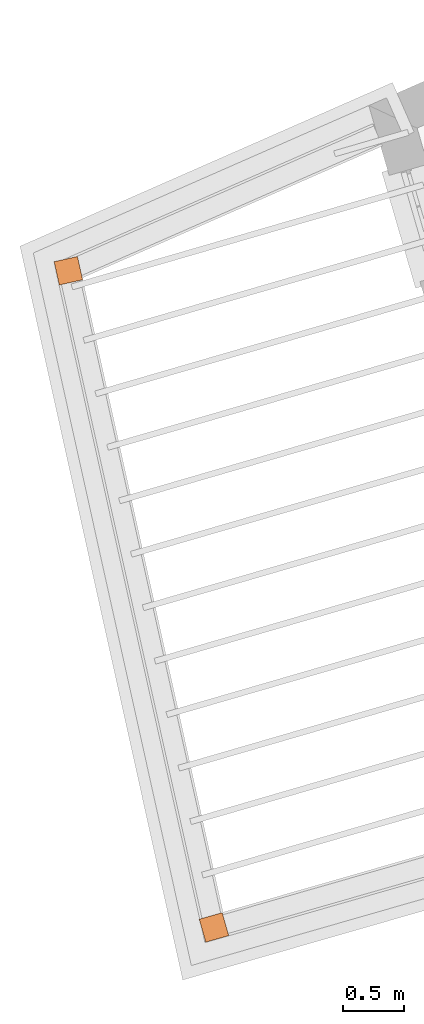
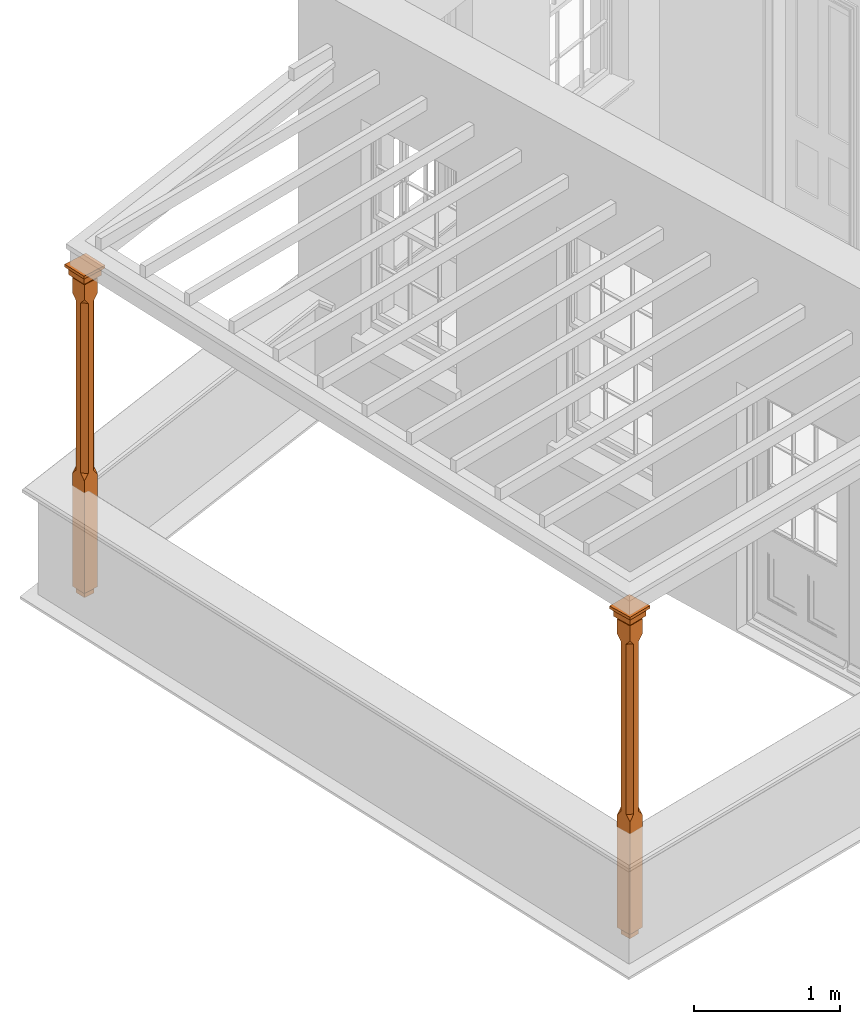
# One storey, part 11 of 11: 2 proxies.
"""IFC2X3 building model written with IfcOpenShell, lengths in metres."""

from ifc_helpers import new_model, si_unit, frame, origin, place, context, subcontext, project, spatial, faceted_brep, element, save


model = new_model("IFC2X3")

# Units and contexts
model_context = context("Model", 3, world=origin())
body_context = subcontext(model_context, "Body", "Model", "MODEL_VIEW")
ifc_project = project(units=[si_unit("PLANEANGLEUNIT", "RADIAN"), si_unit("MASSUNIT", "GRAM", prefix="KILO"), si_unit("FORCEUNIT", "NEWTON", prefix="KILO"), si_unit("LENGTHUNIT", "METRE")], contexts=[model_context])

# Site, building, storey
site_placement = place(None, origin())
site = spatial("IfcSite", under=ifc_project, at=site_placement, CompositionType="ELEMENT")
building_placement = place(None, origin())
building = spatial("IfcBuilding", under=site, at=building_placement, Name="Building plot-15", CompositionType="ELEMENT")
storey_placement = place(None, frame((0.0, 0.0, 7.6)))
storey = spatial("IfcBuildingStorey", under=building, at=storey_placement, Name="Floor 1", CompositionType="ELEMENT", Elevation=7.6)

# Proxies
proxy_1_placement = place(storey_placement, frame((82.8159321906737, 54.848405925525, 0.0), z_axis=(0.0, 0.0, 1.0), x_axis=(0.216502363571399, -0.976282093745449, 0.0)))
element("IfcBuildingElementProxy", 1, at=proxy_1_placement, inside=storey, Name="pergola post", CompositionType="ELEMENT", context=body_context, shape_type="Brep", held_by="IfcProductRepresentation", body=[
    faceted_brep([(0.0246, -0.0615, 2.47), (0.0615, -0.0246, 2.47), (0.0615, -0.0615, 2.516667), (0.0615, -0.0246, 1.044444), (0.0246, -0.0615, 1.044444), (0.0615, 0.0246, 2.47), (0.0615, 0.0615, 2.516667), (-0.0246, -0.0615, 2.47), (-0.0615, -0.0615, 2.516667), (-0.0246, -0.0615, 1.044444), (0.0615, -0.0615, 0.997778), (0.0615, 0.0246, 1.044444), (0.0246, 0.0615, 2.47), (0.0615, 0.0615, 2.641111), (0.0615, -0.0615, 2.641111), (-0.0615, -0.0615, 2.641111), (-0.0615, -0.0246, 2.47), (-0.0615, -0.0246, 1.044444), (-0.0615, -0.0615, 0.997778), (0.0615, 0.0615, 0.997778), (0.0246, 0.0615, 1.044444), (-0.0246, 0.0615, 2.47), (-0.0615, 0.0615, 2.516667), (0.04305, 0.04305, 2.641111), (0.04305, -0.04305, 2.641111), (-0.0615, 0.0615, 2.641111), (-0.04305, -0.04305, 2.641111), (-0.0615, 0.0246, 2.47), (-0.0615, 0.0246, 1.044444), (0.0615, -0.0615, 0.053333), (-0.0615, -0.0615, 0.053333), (0.0615, 0.0615, 0.053333), (-0.0246, 0.0615, 1.044444), (-0.04305, 0.04305, 2.641111), (0.04305, 0.04305, 2.664444), (0.04305, -0.04305, 2.664444), (-0.04305, -0.04305, 2.664444), (-0.0615, 0.0615, 0.997778), (-0.0615, 0.0615, 0.053333), (-0.04305, -0.04305, 0.053333), (0.04305, -0.04305, 0.053333), (0.04305, 0.04305, 0.053333), (-0.04305, 0.04305, 2.664444), (0.07995, 0.07995, 2.664444), (0.07995, -0.07995, 2.664444), (-0.07995, -0.07995, 2.664444), (-0.04305, 0.04305, 0.053333), (-0.04305, -0.04305, 0.0), (0.04305, -0.04305, 0.0), (0.04305, 0.04305, 0.0), (-0.07995, 0.07995, 2.664444), (0.07995, 0.07995, 2.726667), (0.07995, -0.07995, 2.726667), (-0.07995, -0.07995, 2.726667), (-0.04305, 0.04305, 0.0), (-0.07995, 0.07995, 2.726667), (0.0984, 0.0984, 2.726667), (0.0984, -0.0984, 2.726667), (-0.0984, -0.0984, 2.726667), (-0.0984, 0.0984, 2.726667), (0.0984, 0.0984, 2.75), (0.0984, -0.0984, 2.75), (-0.0984, -0.0984, 2.75), (-0.0984, 0.0984, 2.75)], [[[0, 1, 2]], [[3, 1, 0, 4]], [[1, 5, 6, 2]], [[7, 0, 2, 8]], [[4, 0, 7, 9]], [[3, 4, 10]], [[1, 3, 11, 5]], [[5, 12, 6]], [[13, 14, 2, 6]], [[15, 8, 2, 14]], [[8, 16, 7]], [[9, 7, 16, 17]], [[9, 18, 10, 4]], [[3, 10, 19, 11]], [[20, 12, 5, 11]], [[21, 22, 6, 12]], [[14, 13, 23, 24]], [[13, 6, 22, 25]], [[25, 22, 8, 15]], [[26, 15, 14, 24]], [[16, 8, 22, 27]], [[27, 28, 17, 16]], [[17, 18, 9]], [[29, 10, 18, 30]], [[31, 19, 10, 29]], [[20, 11, 19]], [[12, 20, 32, 21]], [[21, 27, 22]], [[33, 23, 13, 25]], [[23, 34, 35, 24]], [[26, 33, 25, 15]], [[36, 26, 24, 35]], [[28, 27, 21, 32]], [[17, 28, 37, 18]], [[38, 30, 18, 37]], [[29, 30, 39, 40]], [[31, 38, 37, 19]], [[40, 41, 31, 29]], [[32, 20, 19, 37]], [[33, 42, 34, 23]], [[43, 44, 35, 34]], [[42, 33, 26, 36]], [[36, 35, 44, 45]], [[28, 32, 37]], [[46, 39, 30, 38]], [[39, 47, 48, 40]], [[46, 38, 31, 41]], [[49, 41, 40, 48]], [[43, 34, 42, 50]], [[43, 51, 52, 44]], [[45, 50, 42, 36]], [[53, 45, 44, 52]], [[46, 54, 47, 39]], [[54, 46, 41, 49]], [[50, 55, 51, 43]], [[56, 57, 52, 51]], [[55, 50, 45, 53]], [[53, 52, 57, 58]], [[56, 51, 55, 59]], [[56, 60, 61, 57]], [[58, 59, 55, 53]], [[62, 58, 57, 61]], [[59, 63, 60, 56]], [[63, 62, 61, 60]], [[58, 62, 63, 59]], [[47, 54, 49, 48]]]),
])
proxy_2_placement = place(storey_placement, frame((84.0149116510646, 49.4418036204089, 0.0), z_axis=(0.0, 0.0, 1.0), x_axis=(0.961140420921365, 0.276059941445879, 0.0)))
element("IfcBuildingElementProxy", 2, at=proxy_2_placement, inside=storey, Name="pergola post", CompositionType="ELEMENT", context=body_context, shape_type="Brep", held_by="IfcProductRepresentation", body=[
    faceted_brep([(0.0246, -0.0615, 2.47), (0.0615, -0.0246, 2.47), (0.0615, -0.0615, 2.516667), (0.0615, -0.0246, 1.044444), (0.0246, -0.0615, 1.044444), (0.0615, 0.0246, 2.47), (0.0615, 0.0615, 2.516667), (-0.0246, -0.0615, 2.47), (-0.0615, -0.0615, 2.516667), (-0.0246, -0.0615, 1.044444), (0.0615, -0.0615, 0.997778), (0.0615, 0.0246, 1.044444), (0.0246, 0.0615, 2.47), (0.0615, 0.0615, 2.641111), (0.0615, -0.0615, 2.641111), (-0.0615, -0.0615, 2.641111), (-0.0615, -0.0246, 2.47), (-0.0615, -0.0246, 1.044444), (-0.0615, -0.0615, 0.997778), (0.0615, 0.0615, 0.997778), (0.0246, 0.0615, 1.044444), (-0.0246, 0.0615, 2.47), (-0.0615, 0.0615, 2.516667), (0.04305, 0.04305, 2.641111), (0.04305, -0.04305, 2.641111), (-0.0615, 0.0615, 2.641111), (-0.04305, -0.04305, 2.641111), (-0.0615, 0.0246, 2.47), (-0.0615, 0.0246, 1.044444), (0.0615, -0.0615, 0.053333), (-0.0615, -0.0615, 0.053333), (0.0615, 0.0615, 0.053333), (-0.0246, 0.0615, 1.044444), (-0.04305, 0.04305, 2.641111), (0.04305, 0.04305, 2.664444), (0.04305, -0.04305, 2.664444), (-0.04305, -0.04305, 2.664444), (-0.0615, 0.0615, 0.997778), (-0.0615, 0.0615, 0.053333), (-0.04305, -0.04305, 0.053333), (0.04305, -0.04305, 0.053333), (0.04305, 0.04305, 0.053333), (-0.04305, 0.04305, 2.664444), (0.07995, 0.07995, 2.664444), (0.07995, -0.07995, 2.664444), (-0.07995, -0.07995, 2.664444), (-0.04305, 0.04305, 0.053333), (-0.04305, -0.04305, 0.0), (0.04305, -0.04305, 0.0), (0.04305, 0.04305, 0.0), (-0.07995, 0.07995, 2.664444), (0.07995, 0.07995, 2.726667), (0.07995, -0.07995, 2.726667), (-0.07995, -0.07995, 2.726667), (-0.04305, 0.04305, 0.0), (-0.07995, 0.07995, 2.726667), (0.0984, 0.0984, 2.726667), (0.0984, -0.0984, 2.726667), (-0.0984, -0.0984, 2.726667), (-0.0984, 0.0984, 2.726667), (0.0984, 0.0984, 2.75), (0.0984, -0.0984, 2.75), (-0.0984, -0.0984, 2.75), (-0.0984, 0.0984, 2.75)], [[[0, 1, 2]], [[3, 1, 0, 4]], [[1, 5, 6, 2]], [[7, 0, 2, 8]], [[4, 0, 7, 9]], [[3, 4, 10]], [[1, 3, 11, 5]], [[5, 12, 6]], [[13, 14, 2, 6]], [[15, 8, 2, 14]], [[8, 16, 7]], [[9, 7, 16, 17]], [[9, 18, 10, 4]], [[3, 10, 19, 11]], [[20, 12, 5, 11]], [[21, 22, 6, 12]], [[14, 13, 23, 24]], [[13, 6, 22, 25]], [[25, 22, 8, 15]], [[26, 15, 14, 24]], [[16, 8, 22, 27]], [[27, 28, 17, 16]], [[17, 18, 9]], [[29, 10, 18, 30]], [[31, 19, 10, 29]], [[20, 11, 19]], [[12, 20, 32, 21]], [[21, 27, 22]], [[33, 23, 13, 25]], [[23, 34, 35, 24]], [[26, 33, 25, 15]], [[36, 26, 24, 35]], [[28, 27, 21, 32]], [[17, 28, 37, 18]], [[38, 30, 18, 37]], [[29, 30, 39, 40]], [[31, 38, 37, 19]], [[40, 41, 31, 29]], [[32, 20, 19, 37]], [[33, 42, 34, 23]], [[43, 44, 35, 34]], [[42, 33, 26, 36]], [[36, 35, 44, 45]], [[28, 32, 37]], [[46, 39, 30, 38]], [[39, 47, 48, 40]], [[46, 38, 31, 41]], [[49, 41, 40, 48]], [[43, 34, 42, 50]], [[43, 51, 52, 44]], [[45, 50, 42, 36]], [[53, 45, 44, 52]], [[46, 54, 47, 39]], [[54, 46, 41, 49]], [[50, 55, 51, 43]], [[56, 57, 52, 51]], [[55, 50, 45, 53]], [[53, 52, 57, 58]], [[56, 51, 55, 59]], [[56, 60, 61, 57]], [[58, 59, 55, 53]], [[62, 58, 57, 61]], [[59, 63, 60, 56]], [[63, 62, 61, 60]], [[58, 62, 63, 59]], [[47, 54, 49, 48]]]),
])

save(model, "model.ifc")
